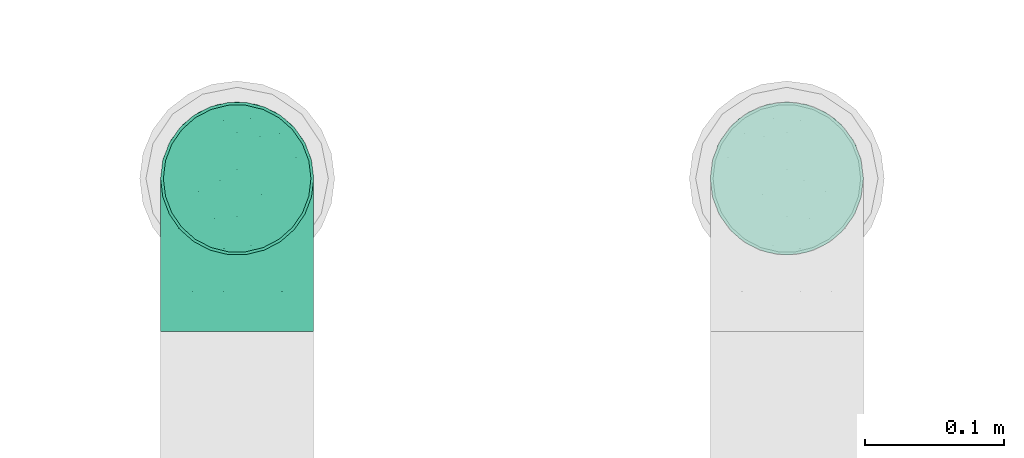
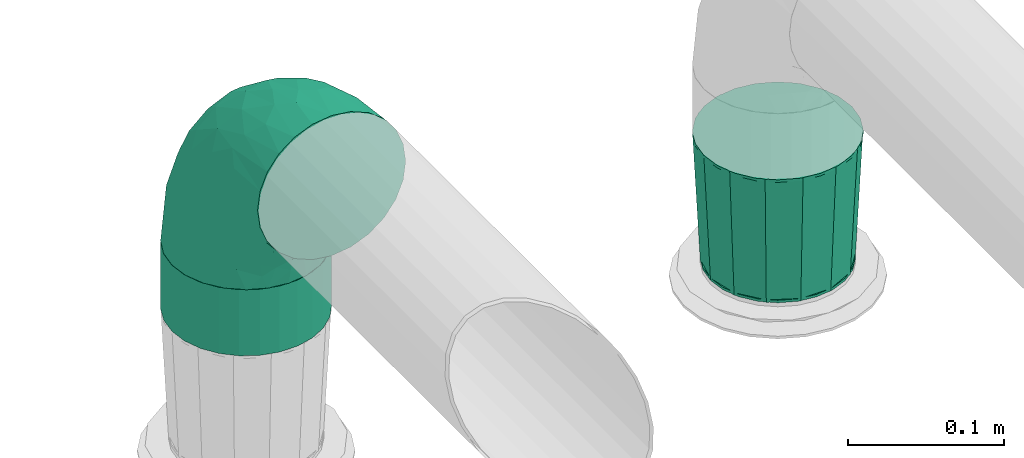
# One storey, part 21 of 115: 2 flow fittings, 1 flow segment.
"""IFC2X3 building model written with IfcOpenShell, lengths in millimetres."""

from ifc_helpers import new_model, entity, si_unit, converted_unit, derived_unit, direction, frame, origin_with_axes, origin_2d_with_axis, place, context, subcontext, project, spatial, hollow_circle, extrude, open_shell, surface_model, source, transform, mapped, material, layer, layer_set, layer_usage, type_object, element, save


model = new_model("IFC2X3")

# Units and contexts
model_context = context("Model", 3, precision=1e-05, world=origin_with_axes(), true_north=direction((0.0, 1.0)))
body_context = subcontext(model_context, "Body", "Model", "MODEL_VIEW")
ifc_project = project(units=[si_unit("AREAUNIT", "SQUARE_METRE"), si_unit("VOLUMEUNIT", "CUBIC_METRE", prefix="DECI"), si_unit("TIMEUNIT", "SECOND"), si_unit("THERMODYNAMICTEMPERATUREUNIT", "DEGREE_CELSIUS"), si_unit("PRESSUREUNIT", "PASCAL"), si_unit("MASSUNIT", "GRAM", prefix="KILO"), si_unit("LENGTHUNIT", "METRE", prefix="MILLI"), si_unit("POWERUNIT", "WATT"), si_unit("ELECTRICCURRENTUNIT", "AMPERE"), si_unit("ELECTRICVOLTAGEUNIT", "VOLT"), derived_unit("VOLUMETRICFLOWRATEUNIT", [(si_unit("VOLUMEUNIT", "CUBIC_METRE", prefix="DECI"), 1), (si_unit("TIMEUNIT", "SECOND"), -1)]), derived_unit("LINEARVELOCITYUNIT", [(si_unit("LENGTHUNIT", "METRE"), 1), (si_unit("TIMEUNIT", "SECOND"), -1)]), derived_unit("MASSDENSITYUNIT", [(si_unit("MASSUNIT", "GRAM", prefix="KILO"), 1), (si_unit("VOLUMEUNIT", "CUBIC_METRE"), -1)]), converted_unit("PLANEANGLEUNIT", "DEGREE", entity("IfcRatioMeasure", 0.01745), si_unit("PLANEANGLEUNIT", "RADIAN"), dimensions=[0, 0, 0, 0, 0, 0, 0])], contexts=[model_context])

# Site, building, storey
site_placement = place(None, origin_with_axes())
site = spatial("IfcSite", under=ifc_project, at=site_placement, CompositionType="ELEMENT")
building_placement = place(site_placement, origin_with_axes())
building = spatial("IfcBuilding", under=site, at=building_placement, Name="mc-building", CompositionType="ELEMENT")
storey_placement = place(building_placement, frame((0.0, 0.0, 2950.0), z_axis=(0.0, 0.0, 1.0), x_axis=(1.0, 0.0, 0.0)))
storey = spatial("IfcBuildingStorey", under=building, at=storey_placement, Name="2. Korrus", CompositionType="ELEMENT", Elevation=2950.0)

# Flow segment
ifc_material = material(Name="FZ1")
ifc_layer = layer(ifc_material, 0.0)
ifc_layer_set = layer_set([ifc_layer], Name="FZ1")
ifc_layer_usage = layer_usage(ifc_layer_set, "AXIS1", "POSITIVE", 0.0)
duct_segment_type = type_object("IfcDuctSegmentType", PredefinedType="RIGIDSEGMENT")
shared_shape_1 = source(origin_with_axes(), body_context, "Body", "SweptSolid", [
    extrude(hollow_circle(Radius=55.0, WallThickness=2.0, at=origin_2d_with_axis()), frame((0.0, 0.0, 0.0), z_axis=(1.0, 0.0, 0.0), x_axis=(0.0, 1.0, 0.0)), (0.0, 0.0, 1.0), 51.9),
])
flow_segment_placement = place(storey_placement, frame((8592.78509, 4693.85998, 2355.0), z_axis=(0.0, 1.0, 0.0), x_axis=(0.0, 0.0, -1.0)))
element("IfcFlowSegment", 1, at=flow_segment_placement, inside=storey, type_object=duct_segment_type, material=ifc_layer_usage, context=body_context, shape_type="MappedRepresentation", body=[
    mapped(shared_shape_1, transform((0.0, 0.0, 0.0), scale=1.0)),
])

# Flow fittings
duct_fitting_type_1 = type_object("IfcDuctFittingType", PredefinedType="TRANSITION")
shared_shape_2 = source(origin_with_axes(), body_context, "Body", "SurfaceModel", [
    surface_model("IfcShellBasedSurfaceModel", [(0.0, 12.94095, 48.29629), (0.0, -35.35534, 35.35534), (0.0, 0.0, 50.0), (0.0, 35.35534, 35.35534), (0.0, 25.0, 43.30127), (0.0, 43.30127, 25.0), (0.0, 48.29629, 12.94095), (0.0, -12.94095, 48.29629), (0.0, -25.0, 43.30127), (0.0, -48.29629, 12.94095), (0.0, -43.30127, 25.0), (0.0, -25.0, -43.30127), (0.0, -48.29629, -12.94095), (0.0, -50.0, 0.0), (0.0, 48.29629, -12.94095), (0.0, 12.94095, -48.29629), (0.0, 43.30127, -25.0), (0.0, 35.35534, -35.35534), (0.0, 25.0, -43.30127), (0.0, -35.35534, -35.35534), (0.0, -43.30127, -25.0), (0.0, -12.94095, -48.29629), (0.0, 0.0, -50.0), (0.0, 50.0, 0.0), (100.0, -55.0, 0.0), (100.0, -12.23865, 53.62104), (100.0, -34.29194, 43.00073), (100.0, 49.55329, -23.86361), (100.0, 12.23865, 53.62104), (100.0, 34.29194, 43.00073), (100.0, 55.0, 0.0), (100.0, 49.55329, 23.86361), (100.0, -49.55329, 23.86361), (100.0, 12.23865, -53.62104), (100.0, -49.55329, -23.86361), (100.0, -34.29194, -43.00073), (100.0, 34.29194, -43.00073), (100.0, -12.23865, -53.62104), (0.0, 11.12605, 48.7464), (0.0, -11.12605, 48.7464), (0.0, 31.17449, 39.09157), (0.0, -45.04844, -21.69419), (0.0, -45.04844, 21.69419), (0.0, -31.17449, 39.09157), (0.0, 45.04844, 21.69419), (0.0, 45.04844, -21.69419), (0.0, 31.17449, -39.09157), (0.0, -31.17449, -39.09157), (0.0, -11.12605, -48.7464), (0.0, 11.12605, -48.7464), (0.0, -47.52422, -10.84709), (100.0, -41.92261, -33.43217), (0.0, -38.11147, -30.39288), (100.0, 41.92261, -33.43217), (0.0, 38.11147, -30.39288), (0.0, -21.15027, -43.91899), (100.0, -23.2653, -48.31088), (100.0, -52.32388, -11.72483), (100.0, 0.0, -53.62104), (0.0, 0.0, -48.7464), (100.0, 23.2653, -48.31088), (0.0, 21.15027, -43.91899), (100.0, 52.32388, -11.72483), (0.0, 47.52422, -10.84709), (0.0, 47.52422, 10.84709), (100.0, 41.92261, 33.43217), (0.0, 38.11147, 30.39288), (100.0, -41.92261, 33.43217), (0.0, -38.11147, 30.39288), (0.0, 21.15027, 43.91899), (100.0, 23.2653, 48.31088), (100.0, 52.32388, 11.72483), (100.0, 0.0, 53.62104), (0.0, 0.0, 48.7464), (100.0, -23.2653, 48.31088), (0.0, -21.15027, 43.91899), (100.0, -52.32388, 11.72483), (0.0, -47.52422, 10.84709), (100.0, 27.5, -47.63139), (100.0, 0.0, -55.0), (100.0, 14.23505, -53.12592), (100.0, 38.89087, -38.89087), (100.0, -27.5, -47.63139), (100.0, 47.63139, -27.5), (100.0, 53.12592, -14.23505), (100.0, -14.23505, -53.12592), (100.0, -47.63139, -27.5), (100.0, -38.89087, -38.89087), (100.0, -53.12592, -14.23505), (100.0, 53.12592, 14.23505), (100.0, 47.63139, 27.5), (100.0, 27.5, 47.63139), (100.0, 38.89087, 38.89087), (100.0, 14.23505, 53.12592), (100.0, 0.0, 55.0), (100.0, -47.63139, 27.5), (100.0, -53.12592, 14.23505), (100.0, -27.5, 47.63139), (100.0, -38.89087, 38.89087), (100.0, -14.23505, 53.12592), (98.0, 0.0, 55.0), (98.0, 14.23505, 53.12592), (98.0, 27.5, 47.63139), (98.0, 38.89087, 38.89087), (98.0, 47.63139, 27.5), (98.0, -47.63139, 27.5), (98.0, 53.12592, -14.23505), (98.0, -27.5, 47.63139), (98.0, -14.23505, 53.12592), (98.0, -38.89087, 38.89087), (98.0, -55.0, 0.0), (98.0, -53.12592, 14.23505), (98.0, 53.12592, 14.23505), (98.0, 47.63139, -27.5), (98.0, -27.5, -47.63139), (98.0, 0.0, -55.0), (98.0, 38.89087, -38.89087), (98.0, 27.5, -47.63139), (98.0, 14.23505, -53.12592), (98.0, -47.63139, -27.5), (98.0, -38.89087, -38.89087), (98.0, -53.12592, -14.23505), (98.0, -14.23505, -53.12592), (98.0, 55.0, 0.0), (2.0, 12.94095, -48.29629), (2.0, 25.0, -43.30127), (2.0, 35.35534, -35.35534), (2.0, 43.30127, -25.0), (2.0, 48.29629, -12.94095), (2.0, 0.0, -50.0), (2.0, 50.0, 0.0), (2.0, -25.0, -43.30127), (2.0, -12.94095, -48.29629), (2.0, -35.35534, -35.35534), (2.0, -48.29629, -12.94095), (2.0, -43.30127, -25.0), (2.0, -48.29629, 12.94095), (2.0, 48.29629, 12.94095), (2.0, 43.30127, 25.0), (2.0, 35.35534, 35.35534), (2.0, -35.35534, 35.35534), (2.0, 12.94095, 48.29629), (2.0, 25.0, 43.30127), (2.0, 0.0, 50.0), (2.0, -43.30127, 25.0), (2.0, -50.0, 0.0), (2.0, -12.94095, 48.29629), (2.0, -25.0, 43.30127)], [open_shell([[[0, 1, 2]], [[3, 0, 4]], [[3, 5, 6]], [[0, 3, 1]], [[6, 1, 3]], [[7, 1, 8]], [[7, 2, 1]], [[1, 9, 10]], [[9, 1, 11]], [[12, 13, 9]], [[11, 1, 6]], [[6, 14, 11]], [[15, 14, 16]], [[17, 18, 15]], [[17, 15, 16]], [[11, 14, 15]], [[12, 19, 20]], [[19, 12, 11]], [[15, 21, 11]], [[12, 9, 11]], [[22, 21, 15]], [[14, 6, 23]], [[24, 25, 26]], [[25, 27, 28]], [[29, 28, 27]], [[27, 30, 31]], [[31, 29, 27]], [[24, 26, 32]], [[33, 24, 34]], [[33, 34, 35]], [[36, 27, 33]], [[33, 27, 24]], [[35, 37, 33]], [[24, 27, 25]], [[38, 23, 39]], [[40, 23, 38]], [[41, 42, 43]], [[41, 13, 42]], [[23, 43, 39]], [[40, 44, 23]], [[41, 23, 45]], [[41, 45, 46]], [[47, 41, 48]], [[49, 48, 41]], [[41, 46, 49]], [[23, 41, 43]], [[34, 50, 41]], [[47, 51, 52]], [[45, 27, 53]], [[36, 54, 53]], [[55, 48, 56]], [[34, 57, 50]], [[57, 13, 50]], [[13, 57, 24]], [[55, 35, 47]], [[35, 51, 47]], [[51, 41, 52]], [[58, 59, 49]], [[60, 61, 46]], [[37, 59, 58]], [[62, 63, 23]], [[35, 55, 56]], [[23, 30, 62]], [[53, 54, 45]], [[48, 37, 56]], [[33, 49, 61]], [[49, 33, 58]], [[54, 36, 46]], [[63, 27, 45]], [[34, 41, 51]], [[33, 61, 60]], [[48, 59, 37]], [[27, 63, 62]], [[46, 36, 60]], [[31, 64, 44]], [[40, 65, 66]], [[42, 32, 67]], [[26, 68, 67]], [[69, 38, 70]], [[31, 71, 64]], [[71, 23, 64]], [[23, 71, 30]], [[69, 29, 40]], [[29, 65, 40]], [[65, 44, 66]], [[72, 73, 39]], [[74, 75, 43]], [[28, 73, 72]], [[76, 77, 13]], [[29, 69, 70]], [[13, 24, 76]], [[67, 68, 42]], [[38, 28, 70]], [[25, 39, 75]], [[39, 25, 72]], [[68, 26, 43]], [[77, 32, 42]], [[31, 44, 65]], [[25, 75, 74]], [[38, 73, 28]], [[32, 77, 76]], [[43, 26, 74]], [[78, 79, 80]], [[81, 82, 78]], [[82, 83, 84]], [[81, 83, 82]], [[30, 82, 84]], [[79, 82, 85]], [[79, 78, 82]], [[82, 86, 87]], [[82, 30, 86]], [[24, 88, 86]], [[86, 30, 89]], [[90, 24, 89]], [[91, 90, 92]], [[91, 93, 94]], [[90, 91, 24]], [[94, 95, 91]], [[24, 95, 96]], [[24, 91, 95]], [[94, 97, 98]], [[98, 95, 94]], [[97, 94, 99]], [[89, 24, 86]], [[100, 101, 102]], [[100, 102, 103]], [[100, 104, 105]], [[104, 100, 103]], [[106, 105, 104]], [[100, 107, 108]], [[100, 109, 107]], [[105, 110, 111]], [[109, 100, 105]], [[105, 106, 110]], [[106, 104, 112]], [[106, 113, 110]], [[113, 114, 110]], [[115, 116, 117]], [[113, 116, 115]], [[117, 118, 115]], [[119, 114, 120]], [[121, 110, 119]], [[114, 115, 122]], [[119, 110, 114]], [[115, 114, 113]], [[123, 106, 112]], [[121, 88, 110]], [[119, 86, 121]], [[82, 120, 114]], [[119, 120, 87]], [[85, 114, 122]], [[121, 86, 88]], [[88, 24, 110]], [[85, 82, 114]], [[87, 120, 82]], [[87, 86, 119]], [[79, 85, 122]], [[122, 115, 79]], [[118, 80, 115]], [[117, 78, 118]], [[83, 116, 113]], [[117, 116, 81]], [[84, 113, 106]], [[117, 81, 78]], [[78, 80, 118]], [[30, 84, 106]], [[83, 113, 84]], [[83, 81, 116]], [[123, 30, 106]], [[115, 80, 79]], [[112, 89, 123]], [[104, 90, 112]], [[91, 103, 102]], [[104, 103, 92]], [[93, 102, 101]], [[112, 90, 89]], [[89, 30, 123]], [[93, 91, 102]], [[92, 103, 91]], [[92, 90, 104]], [[94, 93, 101]], [[101, 100, 94]], [[108, 99, 100]], [[107, 97, 108]], [[95, 109, 105]], [[107, 109, 98]], [[96, 105, 111]], [[107, 98, 97]], [[97, 99, 108]], [[24, 96, 111]], [[95, 105, 96]], [[95, 98, 109]], [[110, 24, 111]], [[100, 99, 94]], [[124, 125, 126]], [[124, 126, 127]], [[124, 128, 129]], [[128, 124, 127]], [[129, 128, 130]], [[129, 131, 132]], [[129, 130, 131]], [[133, 134, 135]], [[134, 133, 131]], [[131, 136, 134]], [[131, 130, 137]], [[137, 138, 139]], [[140, 137, 139]], [[140, 139, 141]], [[141, 139, 142]], [[140, 141, 143]], [[136, 140, 144]], [[145, 134, 136]], [[140, 146, 147]], [[131, 140, 136]], [[143, 146, 140]], [[131, 137, 140]], [[12, 134, 13]], [[20, 135, 12]], [[131, 19, 11]], [[20, 19, 133]], [[132, 11, 21]], [[12, 135, 134]], [[134, 145, 13]], [[132, 131, 11]], [[133, 19, 131]], [[133, 135, 20]], [[129, 132, 21]], [[21, 22, 129]], [[15, 124, 22]], [[18, 125, 15]], [[127, 17, 16]], [[18, 17, 126]], [[128, 16, 14]], [[18, 126, 125]], [[125, 124, 15]], [[130, 128, 14]], [[127, 16, 128]], [[127, 126, 17]], [[23, 130, 14]], [[22, 124, 129]], [[6, 137, 23]], [[5, 138, 6]], [[142, 3, 4]], [[5, 3, 139]], [[141, 4, 0]], [[6, 138, 137]], [[137, 130, 23]], [[141, 142, 4]], [[139, 3, 142]], [[139, 138, 5]], [[143, 141, 0]], [[0, 2, 143]], [[7, 146, 2]], [[8, 147, 7]], [[144, 1, 10]], [[8, 1, 140]], [[136, 10, 9]], [[8, 140, 147]], [[147, 146, 7]], [[145, 136, 9]], [[144, 10, 136]], [[144, 140, 1]], [[13, 145, 9]], [[2, 146, 143]]])]),
])
flow_fitting_1_placement = place(storey_placement, frame((8987.56202, 4693.85998, 2203.1), z_axis=(0.0, -1.0, 0.0), x_axis=(0.0, 0.0, 1.0)))
element("IfcFlowFitting", 2, at=flow_fitting_1_placement, inside=storey, type_object=duct_fitting_type_1, context=body_context, shape_type="MappedRepresentation", body=[
    mapped(shared_shape_2, transform((0.0, 0.0, 0.0), scale=1.0)),
])
duct_fitting_type_2 = type_object("IfcDuctFittingType", Name="BU", PredefinedType="BEND")
shared_shape_3 = source(origin_with_axes(), body_context, "Body", "SurfaceModel", [
    surface_model("IfcShellBasedSurfaceModel", [(-110.0, -38.89087, -38.89087), (-110.0, -55.0, 0.0), (-110.0, -27.5, -47.63139), (-110.0, -53.12592, -14.23505), (-110.0, -47.63139, -27.5), (-110.0, 47.63139, -27.5), (-110.0, 53.12592, 14.23505), (-110.0, 53.12592, -14.23505), (-110.0, -14.23505, -53.12592), (-110.0, 0.0, -55.0), (-110.0, 38.89087, -38.89087), (-110.0, 27.5, -47.63139), (-110.0, 14.23505, -53.12592), (-110.0, 55.0, 0.0), (-110.0, -53.12592, 14.23505), (-110.0, -47.63139, 27.5), (-110.0, -38.89087, 38.89087), (-110.0, 0.0, 55.0), (-110.0, -27.5, 47.63139), (-110.0, -14.23505, 53.12592), (-110.0, 38.89087, 38.89087), (-110.0, 47.63139, 27.5), (-110.0, 27.5, 47.63139), (-110.0, 14.23505, 53.12592), (0.0, -110.0, -55.0), (14.23505, -110.0, -53.12592), (-14.23505, -110.0, -53.12592), (-53.12592, -110.0, 14.23505), (-27.5, -110.0, -47.63139), (-47.63139, -110.0, -27.5), (-38.89087, -110.0, -38.89087), (55.0, -110.0, 0.0), (53.12592, -110.0, 14.23505), (38.89087, -110.0, -38.89087), (27.5, -110.0, -47.63139), (53.12592, -110.0, -14.23505), (47.63139, -110.0, -27.5), (-53.12592, -110.0, -14.23505), (-47.63139, -110.0, 27.5), (-38.89087, -110.0, 38.89087), (14.23505, -110.0, 53.12592), (-27.5, -110.0, 47.63139), (-14.23505, -110.0, 53.12592), (47.63139, -110.0, 27.5), (38.89087, -110.0, 38.89087), (27.5, -110.0, 47.63139), (0.0, -110.0, 55.0), (-55.0, -110.0, 0.0), (-60.44912, -32.56953, 51.94617), (-76.6405, -38.18013, 45.55988), (-64.21732, -48.68956, 43.63444), (-90.15553, -11.94394, 54.09138), (-76.00813, -5.38378, 55.0), (-70.18771, -18.55163, 54.03432), (-78.5998, -26.77405, 50.81338), (-93.27622, -45.77614, 33.48188), (-75.55424, -54.2118, 32.41257), (-96.12334, -22.13664, 50.81337), (-32.04182, -59.64019, 52.24446), (-18.36258, -70.48427, 54.04484), (-21.00813, -45.34362, 55.0), (-63.60674, -66.07878, 29.97482), (-74.66383, -63.08407, 19.92123), (-63.88653, -74.77858, 17.99134), (-93.11138, -56.59448, 10.50359), (-99.597, -52.72185, 18.52927), (-98.21577, -57.34403, 0.0), (-53.42855, -92.60092, 21.04759), (-88.54852, -54.8376, 21.04759), (-5.38378, -76.00813, 55.0), (-11.86161, -90.23965, 54.10313), (-56.64619, -93.12774, 10.22088), (-57.34403, -98.21577, 0.0), (-44.60838, -44.60838, 52.13415), (-45.34362, -21.00813, 55.0), (-92.68484, -35.46673, 43.63443), (-22.25266, -95.40765, 50.81337), (-27.23711, -77.39884, 50.81337), (-43.70931, -69.58671, 44.47149), (-35.97783, -90.61597, 43.63443), (-58.67786, -84.31125, 16.04456), (-57.2828, -79.3123, 24.9774), (-82.93277, -60.36161, 12.91784), (-49.88337, -54.51816, 47.224), (-74.57753, -66.83759, 9.55742), (-45.35812, -94.97281, 33.48188), (-59.18663, -88.95241, 0.0), (-51.517, -78.6292, 33.48188), (-65.14788, -80.03077, 0.0), (-56.45322, -62.06476, 39.63545), (-88.95241, -59.18663, 0.0), (-80.03077, -65.14788, 0.0), (-71.10913, -71.10913, 0.0), (-94.9309, -45.36788, -33.48188), (-93.11358, -56.60141, -10.46614), (-99.64997, -52.79499, -18.30015), (-79.99933, -46.56772, -37.92748), (-90.20425, -36.08686, -43.63443), (-45.34362, -21.00813, -55.0), (-72.75364, -19.68651, -53.60527), (-76.00813, -5.38378, -55.0), (-21.00813, -45.34362, -55.0), (-5.38378, -76.00813, -55.0), (-21.91957, -65.12078, -53.85897), (-35.41876, -92.89265, -43.63443), (-91.10309, -11.02766, -54.21832), (-45.77614, -93.27622, -33.48188), (-90.50474, -23.21022, -50.81337), (-70.92854, -33.31794, -49.51754), (-78.52933, -63.35627, -11.73997), (-24.91508, -84.05606, -50.81337), (-88.78941, -54.74452, -21.04759), (-63.49062, -67.59111, -28.46929), (-73.36422, -62.46673, -22.94182), (-69.59921, -57.34866, -33.48187), (-56.59448, -93.11138, -10.50359), (-54.10679, -75.85581, -32.31867), (-54.8376, -88.54852, -21.04759), (-57.75956, -31.09612, -52.80882), (-52.72185, -99.597, -18.52927), (-12.62913, -89.46304, -53.99097), (-34.46825, -66.46123, -50.04329), (-43.9837, -43.9837, -52.42279), (-65.78527, -72.58348, -17.68796), (-57.47001, -51.99467, -44.91465), (-70.34468, -43.65295, -44.21951), (-60.72547, -82.29174, -12.88567), (-42.34915, -74.24548, -43.63444), (-57.25194, -63.5016, -38.08211), (-80.95344, -53.56991, -29.32027), (-52.32891, -4.55257, -54.0482), (14.95561, -36.05775, -42.26543), (14.88266, -20.92917, -33.7947), (32.52942, -47.13398, -30.48571), (19.3559, -65.35825, -48.00507), (30.24048, -70.09027, -41.7461), (-28.49299, 30.5778, -16.4009), (-47.13398, 32.52942, -30.48571), (-70.35075, 46.44478, -19.5952), (-22.4954, -22.4954, -53.25347), (-4.55257, -52.32891, -54.0482), (-75.47368, 11.22546, -52.60718), (-81.32209, 51.5606, -9.98467), (-70.09027, 30.24048, -41.7461), (-80.81763, 41.84862, -32.14655), (-9.15831, 10.852, -27.8997), (-36.05774, 14.95561, -42.26543), (-65.35825, 19.3559, -48.00507), (3.94376, -43.9333, -50.53315), (11.22546, -75.47368, -52.60718), (-43.9333, 3.94376, -50.53315), (-13.39742, -13.39743, -48.13058), (50.20582, -74.51695, -9.9731), (41.8609, -47.82256, -9.92641), (49.37776, -67.29486, 0.0), (18.93131, -11.7156, -17.56239), (-1.23348, 12.25375, -12.18106), (-27.5, 32.89419, 0.0), (41.84862, -80.81763, -32.14655), (46.44478, -70.35075, -19.5952), (35.70604, -41.31408, -20.38235), (6.67262, 6.67262, 0.0), (32.89419, -27.5, 0.0), (-50.36265, 42.95545, -9.51562), (-67.29486, 49.37776, 0.0), (-5.47251, -5.47251, -39.92906), (-70.35075, 46.44478, 19.5952), (-74.51695, 50.20582, 9.9731), (-47.13398, 32.52942, 30.48571), (-41.31407, 35.70604, 20.38235), (-80.81763, 41.84862, 32.14655), (11.22546, -75.47368, 52.60718), (-4.55257, -52.32891, 54.0482), (-36.05774, 14.95561, 42.26543), (-65.35825, 19.3559, 48.00507), (-43.9333, 3.94376, 50.53315), (-70.09027, 30.24048, 41.7461), (-11.7156, 18.93131, 17.56239), (12.25375, -1.23348, 12.18106), (30.5778, -28.49299, 16.4009), (42.95545, -50.36265, 9.51562), (51.5606, -81.32209, 9.98467), (-52.32891, -4.55257, 54.0482), (-75.47368, 11.22546, 52.60718), (-13.39742, -13.39743, 48.13058), (-22.4954, -22.4954, 53.25347), (3.94376, -43.9333, 50.53315), (-20.92916, 14.88266, 33.79469), (10.852, -9.15831, 27.8997), (-47.82256, 41.8609, 9.92641), (32.52942, -47.13398, 30.48571), (46.44478, -70.35075, 19.5952), (41.84862, -80.81763, 32.14655), (14.95561, -36.05775, 42.26543), (19.3559, -65.35825, 48.00507), (30.24048, -70.09027, 41.7461), (-5.47251, -5.47251, 39.92906)], [open_shell([[[0, 1, 2]], [[3, 1, 4]], [[5, 6, 7]], [[8, 1, 9]], [[2, 1, 8]], [[4, 1, 0]], [[10, 9, 6]], [[9, 10, 11]], [[11, 12, 9]], [[6, 5, 10]], [[7, 6, 13]], [[14, 15, 9]], [[9, 15, 16]], [[17, 16, 18]], [[9, 16, 17]], [[19, 17, 18]], [[9, 20, 21]], [[6, 9, 21]], [[9, 22, 20]], [[23, 22, 9]], [[17, 23, 9]], [[9, 1, 14]], [[24, 25, 26]], [[26, 27, 28]], [[29, 30, 27]], [[28, 27, 30]], [[26, 31, 32]], [[33, 31, 34]], [[25, 34, 31]], [[35, 31, 36]], [[33, 36, 31]], [[31, 26, 25]], [[29, 27, 37]], [[38, 27, 26]], [[39, 38, 26]], [[40, 41, 26]], [[41, 39, 26]], [[40, 42, 41]], [[43, 44, 26]], [[43, 26, 32]], [[44, 45, 26]], [[26, 45, 40]], [[40, 46, 42]], [[47, 37, 27]], [[48, 49, 50]], [[51, 52, 17]], [[48, 53, 54]], [[49, 55, 56]], [[16, 15, 55]], [[18, 57, 19]], [[58, 59, 60]], [[61, 62, 63]], [[64, 65, 14]], [[53, 51, 54]], [[66, 64, 14]], [[27, 38, 67]], [[65, 68, 55]], [[68, 65, 64]], [[69, 59, 70]], [[71, 72, 27]], [[73, 60, 74]], [[55, 49, 75]], [[42, 70, 76]], [[51, 57, 54]], [[77, 78, 79]], [[42, 76, 41]], [[46, 70, 42]], [[55, 68, 56]], [[75, 18, 16]], [[77, 79, 76]], [[80, 67, 81]], [[68, 82, 62]], [[83, 78, 58]], [[82, 84, 62]], [[39, 79, 85]], [[71, 67, 80]], [[72, 71, 86]], [[67, 85, 87]], [[88, 80, 63]], [[39, 41, 79]], [[87, 79, 78]], [[55, 75, 16]], [[50, 89, 83]], [[38, 39, 85]], [[56, 68, 62]], [[61, 87, 89]], [[48, 50, 83]], [[18, 75, 57]], [[54, 75, 49]], [[38, 85, 67]], [[85, 79, 87]], [[56, 62, 61]], [[50, 56, 89]], [[87, 61, 81]], [[90, 64, 66]], [[14, 1, 66]], [[91, 92, 84]], [[82, 90, 91]], [[90, 82, 64]], [[62, 84, 63]], [[84, 82, 91]], [[64, 82, 68]], [[65, 15, 14]], [[15, 65, 55]], [[72, 47, 27]], [[86, 71, 80]], [[67, 71, 27]], [[88, 63, 92]], [[63, 80, 81]], [[63, 81, 61]], [[87, 81, 67]], [[41, 76, 79]], [[70, 59, 77]], [[76, 70, 77]], [[69, 70, 46]], [[77, 59, 58]], [[59, 69, 60]], [[77, 58, 78]], [[73, 58, 60]], [[19, 57, 51]], [[54, 57, 75]], [[19, 51, 17]], [[53, 52, 51]], [[53, 74, 52]], [[73, 74, 48]], [[53, 48, 74]], [[83, 73, 48]], [[73, 83, 58]], [[78, 83, 89]], [[78, 89, 87]], [[61, 89, 56]], [[54, 49, 48]], [[50, 49, 56]], [[88, 86, 80]], [[63, 84, 92]], [[93, 4, 0]], [[66, 94, 90]], [[95, 94, 3]], [[96, 93, 97]], [[98, 99, 100]], [[0, 2, 97]], [[101, 102, 103]], [[104, 28, 30]], [[9, 105, 8]], [[30, 106, 104]], [[107, 105, 99]], [[97, 107, 108]], [[94, 109, 90]], [[2, 8, 107]], [[94, 66, 3]], [[110, 26, 28]], [[94, 111, 109]], [[112, 113, 114]], [[72, 115, 37]], [[116, 106, 117]], [[98, 118, 99]], [[119, 115, 117]], [[115, 119, 37]], [[110, 120, 26]], [[103, 110, 121]], [[117, 106, 119]], [[120, 110, 103]], [[98, 101, 122]], [[117, 123, 116]], [[108, 124, 125]], [[126, 117, 115]], [[30, 29, 106]], [[120, 102, 24]], [[110, 104, 127]], [[97, 125, 96]], [[118, 122, 124]], [[124, 127, 128]], [[93, 0, 97]], [[86, 126, 115]], [[127, 106, 116]], [[129, 113, 111]], [[4, 93, 95]], [[114, 129, 96]], [[28, 104, 110]], [[127, 104, 106]], [[2, 107, 97]], [[108, 107, 99]], [[118, 108, 99]], [[100, 99, 105]], [[128, 112, 114]], [[127, 124, 121]], [[66, 1, 3]], [[91, 90, 109]], [[95, 111, 94]], [[109, 123, 92]], [[114, 113, 129]], [[111, 95, 93]], [[95, 3, 4]], [[86, 115, 72]], [[37, 47, 72]], [[88, 92, 123]], [[123, 117, 126]], [[126, 88, 123]], [[88, 126, 86]], [[119, 29, 37]], [[29, 119, 106]], [[111, 93, 129]], [[124, 114, 125]], [[100, 105, 9]], [[8, 105, 107]], [[108, 118, 124]], [[122, 118, 98]], [[96, 129, 93]], [[109, 111, 113]], [[113, 123, 109]], [[116, 123, 112]], [[113, 112, 123]], [[116, 112, 128]], [[116, 128, 127]], [[124, 128, 114]], [[103, 122, 101]], [[127, 121, 110]], [[121, 122, 103]], [[122, 121, 124]], [[26, 120, 24]], [[102, 120, 103]], [[108, 125, 97]], [[109, 92, 91]], [[96, 125, 114]], [[100, 130, 98]], [[131, 132, 133]], [[134, 135, 34]], [[136, 137, 138]], [[101, 139, 140]], [[9, 141, 100]], [[138, 7, 142]], [[137, 143, 144]], [[142, 7, 13]], [[145, 146, 137]], [[146, 147, 143]], [[5, 138, 144]], [[7, 138, 5]], [[5, 144, 10]], [[140, 148, 149]], [[143, 11, 10]], [[147, 12, 11]], [[100, 141, 130]], [[98, 139, 101]], [[148, 134, 149]], [[139, 150, 151]], [[152, 153, 154]], [[150, 139, 130]], [[25, 24, 149]], [[141, 12, 147]], [[132, 145, 155]], [[156, 136, 157]], [[158, 33, 135]], [[148, 139, 151]], [[36, 33, 158]], [[34, 135, 33]], [[159, 160, 153]], [[160, 159, 133]], [[137, 146, 143]], [[152, 154, 31]], [[137, 136, 145]], [[161, 162, 155]], [[133, 159, 158]], [[134, 148, 131]], [[163, 164, 157]], [[163, 142, 164]], [[102, 101, 140]], [[162, 154, 153]], [[159, 35, 36]], [[155, 156, 161]], [[131, 165, 132]], [[155, 145, 156]], [[98, 130, 139]], [[150, 130, 141]], [[147, 150, 141]], [[9, 12, 141]], [[149, 24, 102]], [[148, 140, 139]], [[140, 149, 102]], [[34, 25, 134]], [[146, 151, 150]], [[143, 147, 11]], [[147, 146, 150]], [[145, 165, 146]], [[25, 149, 134]], [[135, 134, 131]], [[135, 131, 133]], [[151, 165, 131]], [[148, 151, 131]], [[165, 151, 146]], [[160, 133, 132]], [[132, 165, 145]], [[36, 158, 159]], [[133, 158, 135]], [[10, 144, 143]], [[137, 144, 138]], [[162, 153, 155]], [[159, 153, 152]], [[160, 155, 153]], [[155, 160, 132]], [[152, 35, 159]], [[35, 152, 31]], [[136, 138, 163]], [[164, 142, 13]], [[142, 163, 138]], [[136, 163, 157]], [[161, 156, 157]], [[136, 156, 145]], [[166, 6, 21]], [[167, 164, 13]], [[166, 168, 169]], [[170, 168, 166]], [[69, 171, 172]], [[173, 174, 175]], [[174, 176, 22]], [[161, 157, 177]], [[170, 20, 176]], [[21, 20, 170]], [[178, 179, 162]], [[180, 181, 154]], [[182, 175, 183]], [[183, 23, 17]], [[184, 185, 186]], [[74, 185, 182]], [[52, 74, 182]], [[187, 188, 177]], [[166, 169, 189]], [[190, 179, 188]], [[22, 176, 20]], [[180, 154, 162]], [[32, 191, 43]], [[192, 44, 43]], [[43, 191, 192]], [[32, 31, 181]], [[193, 194, 195]], [[194, 40, 45]], [[190, 193, 195]], [[45, 44, 195]], [[69, 46, 171]], [[74, 60, 185]], [[157, 164, 189]], [[167, 189, 164]], [[172, 60, 69]], [[185, 172, 186]], [[173, 187, 168]], [[191, 32, 181]], [[190, 195, 192]], [[179, 190, 191]], [[175, 174, 183]], [[171, 40, 194]], [[188, 193, 190]], [[175, 185, 184]], [[177, 178, 161]], [[173, 196, 187]], [[177, 188, 178]], [[60, 172, 185]], [[186, 172, 171]], [[194, 186, 171]], [[46, 40, 171]], [[183, 17, 52]], [[175, 182, 185]], [[182, 183, 52]], [[22, 23, 174]], [[193, 184, 186]], [[195, 194, 45]], [[194, 193, 186]], [[188, 196, 193]], [[23, 183, 174]], [[176, 174, 173]], [[176, 173, 168]], [[184, 196, 173]], [[175, 184, 173]], [[196, 184, 193]], [[169, 168, 187]], [[187, 196, 188]], [[21, 170, 166]], [[168, 170, 176]], [[44, 192, 195]], [[190, 192, 191]], [[157, 189, 177]], [[166, 189, 167]], [[169, 177, 189]], [[177, 169, 187]], [[167, 6, 166]], [[6, 167, 13]], [[179, 191, 180]], [[154, 181, 31]], [[181, 180, 191]], [[179, 180, 162]], [[161, 178, 162]], [[179, 178, 188]]])]),
])
flow_fitting_2_placement = place(storey_placement, frame((8592.78509, 4693.85998, 2465.0), z_axis=(1.0, 0.0, 0.0), x_axis=(0.0, 1.0, 0.0)))
element("IfcFlowFitting", 3, at=flow_fitting_2_placement, inside=storey, type_object=duct_fitting_type_2, Name="BU", context=body_context, shape_type="MappedRepresentation", body=[
    mapped(shared_shape_3, transform((0.0, 0.0, 0.0), scale=1.0)),
])

save(model, "model.ifc")
